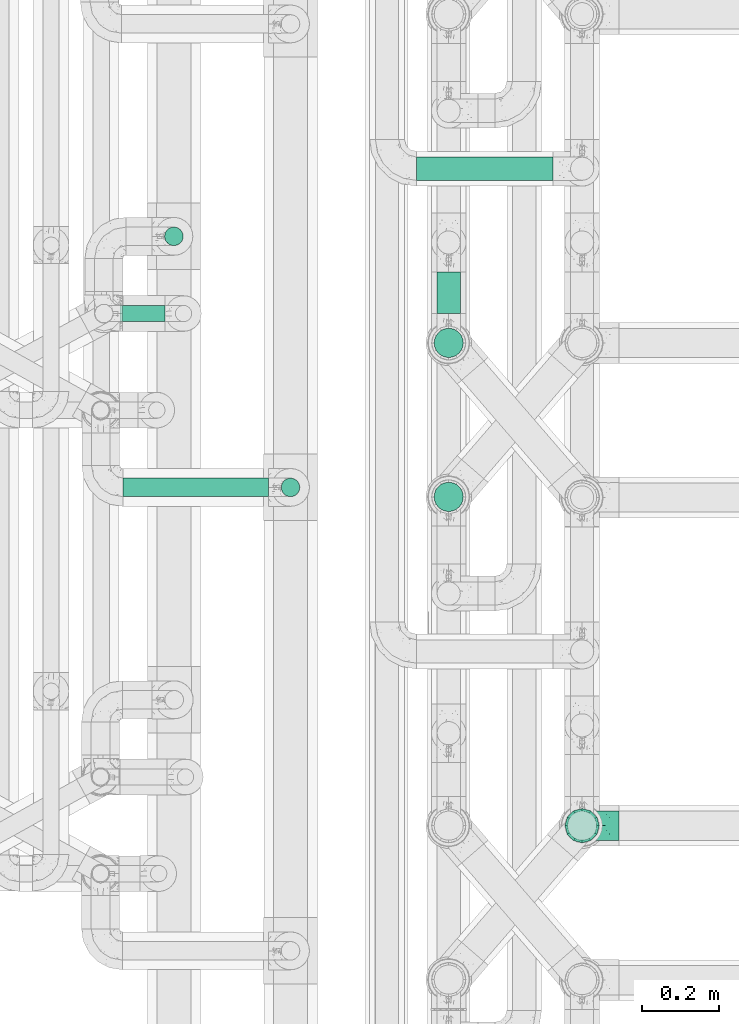
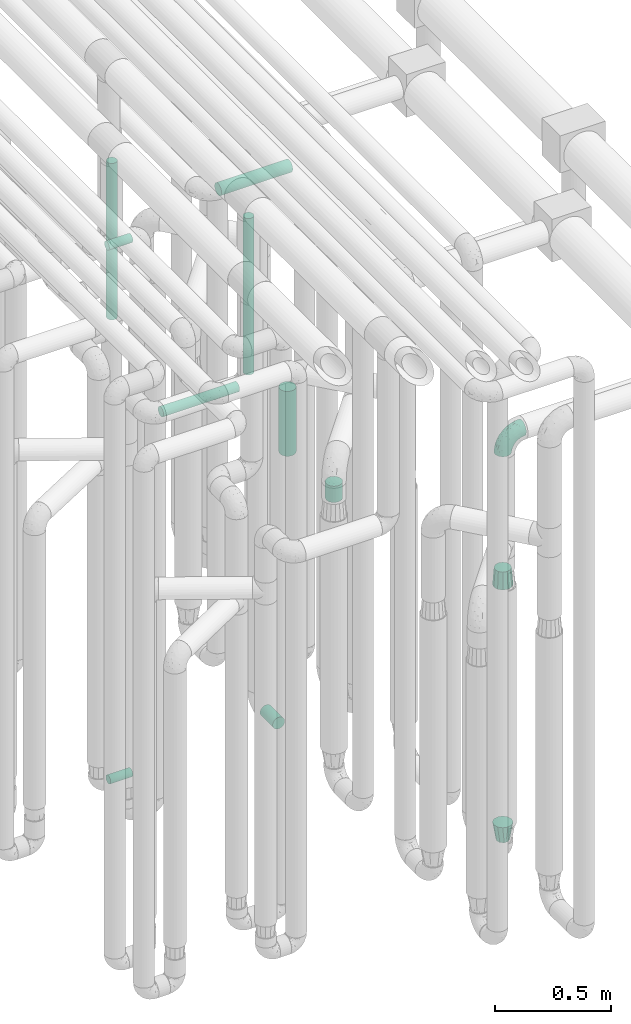
# One storey, part 614 of 827: 9 flow segments, 3 flow fittings.
"""IFC2X3 building model written with IfcOpenShell, lengths in millimetres."""

from ifc_helpers import new_model, entity, si_unit, converted_unit, derived_unit, direction, frame, origin, origin_2d_with_axis, place, context, subcontext, project, spatial, polyline, circle, outline, extrude, faceted_brep, source, transform, mapped, material, type_object, type_shapes, element, save


model = new_model("IFC2X3")

# Units and contexts
model_context = context("Model", 3, precision=0.01, world=origin(), true_north=direction((6.12303176911189e-17, 1.0)))
body_context = subcontext(model_context, "Body", "Model", "MODEL_VIEW")
ifc_project = project(units=[si_unit("LENGTHUNIT", "METRE", prefix="MILLI"), si_unit("AREAUNIT", "SQUARE_METRE"), si_unit("VOLUMEUNIT", "CUBIC_METRE"), converted_unit("PLANEANGLEUNIT", "DEGREE", entity("IfcRatioMeasure", 0.0174532925199433), si_unit("PLANEANGLEUNIT", "RADIAN"), dimensions=[0, 0, 0, 0, 0, 0, 0]), si_unit("MASSUNIT", "GRAM", prefix="KILO"), derived_unit("MASSDENSITYUNIT", [(si_unit("MASSUNIT", "GRAM", prefix="KILO"), 1), (si_unit("LENGTHUNIT", "METRE"), -3)]), derived_unit("MOMENTOFINERTIAUNIT", [(si_unit("LENGTHUNIT", "METRE"), 4)]), si_unit("TIMEUNIT", "SECOND"), si_unit("FREQUENCYUNIT", "HERTZ"), si_unit("THERMODYNAMICTEMPERATUREUNIT", "DEGREE_CELSIUS"), derived_unit("THERMALTRANSMITTANCEUNIT", [(si_unit("MASSUNIT", "GRAM", prefix="KILO"), 1), (si_unit("THERMODYNAMICTEMPERATUREUNIT", "KELVIN"), -1), (si_unit("TIMEUNIT", "SECOND"), -3)]), derived_unit("VOLUMETRICFLOWRATEUNIT", [(si_unit("LENGTHUNIT", "METRE"), 3), (si_unit("TIMEUNIT", "SECOND"), -1)]), derived_unit("MASSFLOWRATEUNIT", [(si_unit("MASSUNIT", "GRAM", prefix="KILO"), 1), (si_unit("TIMEUNIT", "SECOND"), -1)]), derived_unit("ROTATIONALFREQUENCYUNIT", [(si_unit("TIMEUNIT", "SECOND"), -1)]), si_unit("ELECTRICCURRENTUNIT", "AMPERE"), si_unit("ELECTRICVOLTAGEUNIT", "VOLT"), si_unit("POWERUNIT", "WATT"), si_unit("FORCEUNIT", "NEWTON", prefix="KILO"), si_unit("ILLUMINANCEUNIT", "LUX"), si_unit("LUMINOUSFLUXUNIT", "LUMEN"), si_unit("LUMINOUSINTENSITYUNIT", "CANDELA"), derived_unit("USERDEFINED", [(si_unit("MASSUNIT", "GRAM", prefix="KILO"), -1), (si_unit("LENGTHUNIT", "METRE"), -2), (si_unit("TIMEUNIT", "SECOND"), 3), (si_unit("LUMINOUSFLUXUNIT", "LUMEN"), 1)]), derived_unit("LINEARVELOCITYUNIT", [(si_unit("LENGTHUNIT", "METRE"), 1), (si_unit("TIMEUNIT", "SECOND"), -1)]), si_unit("PRESSUREUNIT", "PASCAL"), derived_unit("USERDEFINED", [(si_unit("LENGTHUNIT", "METRE"), -2), (si_unit("MASSUNIT", "GRAM", prefix="KILO"), 1), (si_unit("TIMEUNIT", "SECOND"), -2)]), derived_unit("LINEARFORCEUNIT", [(si_unit("MASSUNIT", "GRAM", prefix="KILO"), 1), (si_unit("LENGTHUNIT", "METRE"), 1), (si_unit("TIMEUNIT", "SECOND"), -2), (si_unit("LENGTHUNIT", "METRE"), -1)]), derived_unit("PLANARFORCEUNIT", [(si_unit("MASSUNIT", "GRAM", prefix="KILO"), 1), (si_unit("LENGTHUNIT", "METRE"), 1), (si_unit("TIMEUNIT", "SECOND"), -2), (si_unit("LENGTHUNIT", "METRE"), -2)])], contexts=[model_context])

# Site, building, storey
site_placement = place(None, origin())
site = spatial("IfcSite", under=ifc_project, at=site_placement, CompositionType="ELEMENT")
building_placement = place(site_placement, origin())
building = spatial("IfcBuilding", under=site, at=building_placement, CompositionType="ELEMENT")
storey_placement = place(building_placement, frame((0.0, 0.0, 28200.0)))
storey = spatial("IfcBuildingStorey", under=building, at=storey_placement, Name="08", CompositionType="ELEMENT", Elevation=28200.0)

# Flow segments
pipe_segment_type = type_object("IfcPipeSegmentType", PredefinedType="NOTDEFINED")
flow_segment_1_placement = place(storey_placement, frame((36546.03, 12149.58, 2968.4)))
element("IfcFlowSegment", 1, at=flow_segment_1_placement, inside=storey, type_object=pipe_segment_type, context=body_context, shape_type="SweptSolid", body=[
    extrude(circle(Radius=30.0, at=origin_2d_with_axis()), frame((0.0, 31.6, 31.6), z_axis=(1.0, 0.0, 0.0), x_axis=(0.0, -1.0, 0.0)), (0.0, 0.0, 1.0), 352.999982000026),
])
flow_segment_2_placement = place(storey_placement, frame((36598.05, 11806.2, 368.4)))
element("IfcFlowSegment", 2, at=flow_segment_2_placement, inside=storey, type_object=pipe_segment_type, context=body_context, shape_type="SweptSolid", body=[
    extrude(circle(Radius=30.0, at=origin_2d_with_axis()), frame((31.6, 0.0, 31.6), z_axis=(0.0, 1.0, 0.0), x_axis=(-1.0, 0.0, 0.0)), (0.0, 0.0, 1.0), 108.000000000014),
])
flow_segment_3_placement = place(storey_placement, frame((36590.3, 11690.86, 1870.0)))
element("IfcFlowSegment", 3, at=flow_segment_3_placement, inside=storey, type_object=pipe_segment_type, context=body_context, shape_type="SweptSolid", body=[
    extrude(circle(Radius=37.75, at=origin_2d_with_axis()), frame((39.35, 39.35, 0.0)), (0.0, 0.0, 1.0), 340.000000000014),
])
flow_segment_4_placement = place(storey_placement, frame((36590.3, 11292.25, 1870.0)))
element("IfcFlowSegment", 4, at=flow_segment_4_placement, inside=storey, type_object=pipe_segment_type, context=body_context, shape_type="SweptSolid", body=[
    extrude(circle(Radius=37.75, at=origin_2d_with_axis()), frame((39.35, 39.35, 0.0)), (0.0, 0.0, 1.0), 84.9999999999937),
])
flow_segment_5_placement = place(storey_placement, frame((35784.85, 11783.46, 377.25)))
element("IfcFlowSegment", 5, at=flow_segment_5_placement, inside=storey, type_object=pipe_segment_type, context=body_context, shape_type="SweptSolid", body=[
    extrude(circle(Radius=21.15, at=origin_2d_with_axis()), frame((0.0, 22.75, 22.75), z_axis=(1.0, 0.0, 0.0), x_axis=(0.0, 1.0, 0.0)), (0.0, 0.0, 1.0), 110.194459668835),
])
flow_segment_6_placement = place(storey_placement, frame((35778.03, 11783.46, 3177.25)))
element("IfcFlowSegment", 6, at=flow_segment_6_placement, inside=storey, type_object=pipe_segment_type, context=body_context, shape_type="SweptSolid", body=[
    extrude(circle(Radius=21.15, at=origin_2d_with_axis()), frame((0.0, 22.75, 22.75), z_axis=(1.0, 0.0, 0.0), x_axis=(0.0, 1.0, 0.0)), (0.0, 0.0, 1.0), 117.013860378015),
])
flow_segment_7_placement = place(storey_placement, frame((35892.47, 11980.49, 2657.0)))
element("IfcFlowSegment", 7, at=flow_segment_7_placement, inside=storey, type_object=pipe_segment_type, context=body_context, shape_type="SweptSolid", body=[
    extrude(circle(Radius=24.0, at=origin_2d_with_axis()), frame((25.6, 25.6, 0.0)), (0.0, 0.0, 1.0), 820.000751547978),
])
flow_segment_8_placement = place(storey_placement, frame((35785.78, 11330.49, 2574.4)))
element("IfcFlowSegment", 8, at=flow_segment_8_placement, inside=storey, type_object=pipe_segment_type, context=body_context, shape_type="SweptSolid", body=[
    extrude(circle(Radius=24.0, at=origin_2d_with_axis()), frame((0.0, 25.6, 25.6), z_axis=(1.0, 0.0, 0.0), x_axis=(0.0, -1.0, 0.0)), (0.0, 0.0, 1.0), 377.249999999815),
])
flow_segment_9_placement = place(storey_placement, frame((36194.44, 11330.49, 2657.0)))
element("IfcFlowSegment", 9, at=flow_segment_9_placement, inside=storey, type_object=pipe_segment_type, context=body_context, shape_type="SweptSolid", body=[
    extrude(outline(polyline([(-3.13, -23.79), (3.13, -23.79), (9.18, -22.17), (14.61, -19.04), (19.04, -14.61), (22.17, -9.18), (23.79, -3.13), (23.79, 3.13), (22.17, 9.18), (19.04, 14.61), (14.61, 19.04), (9.18, 22.17), (3.13, 23.79), (-3.13, 23.79), (-9.18, 22.17), (-14.61, 19.04), (-19.04, 14.61), (-22.17, 9.18), (-23.79, 3.13), (-23.79, -3.13), (-22.17, -9.18), (-19.04, -14.61), (-14.61, -19.04), (-9.18, -22.17), (-3.13, -23.79)])), frame((25.6, 25.6, 0.0), z_axis=(0.0, -8.11528883373535e-09, 1.0), x_axis=(-0.130526192219642, 0.991444861373864, 8.04589959840434e-09)), (0.0, 0.0, 1.0), 820.00018792874),
])

# Flow fittings
ifc_material = material()
pipe_fitting_type_1 = type_object("IfcPipeFittingType", Name="ADSK_1", PredefinedType="NOTDEFINED", material=ifc_material)
shared_shape_1 = source(origin(), body_context, "Body", "Brep", [
    faceted_brep([(-95.0, 19.02, -32.95), (-95.0, 9.85, -36.75), (-95.0, 0.0, -38.05), (-95.0, -9.85, -36.75), (-95.0, -19.03, -32.95), (-95.0, -26.91, -26.91), (-95.0, -32.95, -19.03), (-95.0, -36.75, -9.85), (-95.0, -38.05, 0.0), (-95.0, -36.75, 9.85), (-95.0, -32.95, 19.02), (-95.0, -26.91, 26.91), (-95.0, -19.03, 32.95), (-95.0, -9.85, 36.75), (-95.0, 0.0, 38.05), (-95.0, 9.85, 36.75), (-95.0, 19.02, 32.95), (-95.0, 26.91, 26.91), (-95.0, 32.95, 19.02), (-95.0, 36.75, 9.85), (-95.0, 38.05, 0.0), (-95.0, 36.75, -9.85), (-95.0, 32.95, -19.03), (-95.0, 26.91, -26.91), (0.0, 95.0, -38.05), (-9.85, 95.0, -36.75), (-19.02, 95.0, -32.95), (-26.91, 95.0, -26.91), (-32.95, 95.0, -19.03), (-36.75, 95.0, -9.85), (-38.05, 95.0, 0.0), (-36.75, 95.0, 9.85), (-32.95, 95.0, 19.02), (-26.91, 95.0, 26.91), (-19.02, 95.0, 32.95), (-9.85, 95.0, 36.75), (0.0, 95.0, 38.05), (9.85, 95.0, 36.75), (19.03, 95.0, 32.95), (26.91, 95.0, 26.91), (32.95, 95.0, 19.02), (36.75, 95.0, 9.85), (38.05, 95.0, 0.0), (36.75, 95.0, -9.85), (32.95, 95.0, -19.03), (26.91, 95.0, -26.91), (19.03, 95.0, -32.95), (9.85, 95.0, -36.75), (-7.99, -4.96, 6.3), (-0.92, 0.92, 0.0), (4.62, 8.1, 8.01), (-76.19, -35.57, 0.0), (-64.32, -32.32, 12.43), (20.51, 62.45, 28.68), (-60.56, -33.52, 0.0), (-70.4, -13.47, 34.42), (-39.61, -5.88, 32.32), (-49.6, 2.07, 37.1), (-70.34, -28.81, 21.71), (14.64, 40.81, 26.5), (5.88, 39.61, 32.32), (3.59, 20.77, 25.31), (-40.45, 68.06, 16.75), (-62.45, -20.51, 28.68), (-44.52, -26.87, 0.0), (-28.47, -20.22, 0.0), (-26.43, -17.83, 8.75), (-76.1, 39.63, 10.76), (-72.74, 37.58, 18.19), (-60.35, 46.18, 14.61), (-13.4, 13.4, 32.12), (-20.77, -3.59, 25.31), (-14.66, 81.47, 35.56), (-6.22, 71.26, 37.92), (-57.5, 42.48, 22.79), (-15.0, 34.74, 37.7), (-27.1, 12.08, 36.05), (-9.2, 28.81, 35.63), (-79.98, 23.7, 30.95), (-73.68, -4.3, 37.48), (-30.74, 21.67, 37.97), (-62.36, 47.59, 6.79), (-72.71, 32.83, 24.69), (-67.42, 7.02, 37.95), (-32.13, 75.27, 24.51), (-43.46, 51.47, 26.26), (-24.98, 73.15, 31.29), (20.59, 41.28, 19.85), (7.79, 16.09, 15.86), (-73.21, 42.39, 0.0), (-54.73, 54.73, 0.0), (-73.44, 15.79, 35.79), (-5.94, 4.32, 20.43), (28.81, 70.34, 21.71), (32.32, 64.32, 12.43), (-53.59, 26.2, 35.09), (-52.02, 19.31, 37.21), (21.38, 33.53, 10.34), (26.87, 44.52, 0.0), (-48.28, 12.14, 38.05), (4.3, 73.68, 37.48), (-44.08, -25.52, 12.79), (-41.28, -20.59, 19.85), (35.57, 76.19, 0.0), (-47.26, 54.3, 20.18), (-47.4, 61.99, 8.58), (-42.39, 73.21, 0.0), (-39.67, 78.86, 7.21), (-45.69, 36.84, 33.11), (-32.83, 50.13, 33.35), (13.47, 70.4, 34.42), (-18.25, 63.73, 36.07), (-40.63, -13.75, 27.22), (-16.63, 46.37, 37.95), (-53.47, 38.79, 28.59), (-26.07, 48.54, 36.15), (-34.51, 34.51, 36.86), (-2.07, 49.6, 37.1), (-22.79, -10.49, 19.23), (-61.73, 28.67, 31.87), (9.65, 14.7, 0.0), (20.22, 28.47, 0.0), (33.52, 60.56, 0.0), (-11.42, -5.44, 13.25), (-14.7, -9.65, 0.0), (-81.47, 14.66, -35.56), (-62.45, -20.51, -28.68), (-71.26, 6.22, -37.92), (-75.27, 32.13, -24.51), (-73.15, 24.98, -31.29), (13.47, 70.4, -34.42), (5.88, 39.61, -32.32), (-2.07, 49.6, -37.1), (-78.86, 39.67, -7.21), (-70.4, -13.47, -34.42), (-39.61, -5.88, -32.32), (-61.99, 47.4, -8.58), (32.32, 64.32, -12.43), (28.81, 70.34, -21.71), (-63.73, 18.25, -36.07), (-50.13, 32.83, -33.35), (4.3, 73.68, -37.48), (-7.02, 67.42, -37.95), (-39.63, 76.1, -10.76), (-46.18, 60.35, -14.61), (-47.59, 62.36, -6.79), (-64.32, -32.32, -12.43), (-26.2, 53.59, -35.09), (-15.79, 73.44, -35.79), (-19.31, 52.02, -37.21), (-37.58, 72.74, -18.19), (-70.34, -28.81, -21.71), (-42.48, 57.5, -22.79), (-38.79, 53.47, -28.59), (-51.47, 43.46, -26.26), (-32.83, 72.71, -24.69), (-46.37, 16.63, -37.95), (-73.68, -4.3, -37.48), (-41.28, -20.59, -19.85), (-44.08, -25.52, -12.79), (13.75, 40.63, -27.22), (20.51, 62.45, -28.68), (-68.06, 40.45, -16.75), (-54.3, 47.26, -20.18), (-12.14, 48.28, -38.05), (-21.67, 30.74, -37.97), (-36.84, 45.69, -33.11), (-11.42, -5.44, -13.25), (7.79, 16.09, -15.86), (4.62, 8.1, -8.01), (-23.7, 79.98, -30.95), (-26.43, -17.83, -8.75), (-7.99, -4.96, -6.3), (-40.81, -14.64, -26.5), (-20.77, -3.59, -25.31), (-34.74, 15.0, -37.7), (-12.08, 27.1, -36.05), (-28.81, 9.2, -35.63), (-22.79, -10.49, -19.23), (21.38, 33.53, -10.34), (20.59, 41.28, -19.85), (-48.54, 26.07, -36.15), (-49.6, 2.07, -37.1), (-13.4, 13.4, -32.12), (3.59, 20.77, -25.31), (-28.67, 61.73, -31.87), (-34.51, 34.51, -36.86), (-5.94, 4.32, -20.43)], [[[0, 1, 2, 3, 4, 5, 6, 7, 8, 9, 10, 11, 12, 13, 14, 15, 16, 17, 18, 19, 20, 21, 22, 23]], [[24, 25, 26, 27, 28, 29, 30, 31, 32, 33, 34, 35, 36, 37, 38, 39, 40, 41, 42, 43, 44, 45, 46, 47]], [[48, 49, 50]], [[51, 52, 9]], [[53, 39, 38]], [[9, 52, 10]], [[54, 52, 51]], [[55, 56, 57]], [[11, 10, 58]], [[59, 60, 61]], [[32, 31, 62]], [[63, 12, 11]], [[63, 55, 12]], [[64, 65, 66]], [[67, 68, 69]], [[70, 56, 71]], [[35, 72, 73]], [[69, 68, 74]], [[75, 76, 77]], [[16, 78, 17]], [[13, 79, 14]], [[76, 75, 80]], [[67, 69, 81]], [[18, 17, 82]], [[14, 79, 83]], [[20, 19, 67]], [[84, 85, 86]], [[87, 61, 88]], [[89, 81, 90]], [[18, 82, 68]], [[15, 91, 16]], [[14, 83, 15]], [[71, 92, 61]], [[17, 78, 82]], [[93, 87, 94]], [[95, 91, 96]], [[97, 98, 94]], [[86, 72, 34]], [[96, 99, 80]], [[37, 36, 100]], [[40, 39, 93]], [[40, 94, 41]], [[64, 66, 101]], [[93, 94, 40]], [[58, 102, 63]], [[94, 103, 41]], [[94, 87, 97]], [[104, 69, 74]], [[34, 33, 86]], [[105, 69, 104]], [[52, 58, 10]], [[106, 107, 30]], [[108, 109, 85]], [[105, 106, 90]], [[53, 110, 60]], [[86, 111, 72]], [[86, 109, 111]], [[33, 84, 86]], [[12, 55, 13]], [[112, 56, 63]], [[110, 38, 37]], [[34, 72, 35]], [[36, 35, 73]], [[111, 113, 73]], [[105, 107, 106]], [[110, 53, 38]], [[74, 114, 85]], [[91, 15, 83]], [[105, 90, 81]], [[107, 62, 31]], [[33, 32, 84]], [[115, 109, 116]], [[111, 115, 113]], [[100, 73, 117]], [[56, 55, 63]], [[79, 55, 57]], [[102, 118, 112]], [[56, 70, 76]], [[100, 110, 37]], [[117, 77, 60]], [[117, 60, 110]], [[60, 70, 61]], [[58, 52, 101]], [[63, 11, 58]], [[39, 53, 93]], [[87, 93, 53]], [[96, 91, 83]], [[78, 91, 119]], [[32, 62, 84]], [[84, 62, 104]], [[86, 85, 109]], [[85, 114, 108]], [[80, 113, 116]], [[117, 73, 113]], [[80, 116, 96]], [[80, 57, 76]], [[71, 112, 118]], [[61, 87, 59]], [[62, 107, 105]], [[97, 120, 121]], [[70, 71, 61]], [[71, 118, 92]], [[73, 100, 36]], [[110, 100, 117]], [[55, 79, 13]], [[83, 79, 57]], [[96, 83, 99]], [[116, 108, 95]], [[50, 97, 88]], [[97, 87, 88]], [[50, 49, 120]], [[122, 94, 98]], [[89, 20, 67]], [[105, 81, 69]], [[89, 67, 81]], [[68, 19, 18]], [[68, 67, 19]], [[74, 68, 82]], [[114, 82, 119]], [[74, 85, 104]], [[82, 114, 74]], [[114, 119, 108]], [[95, 108, 119]], [[116, 109, 108]], [[123, 48, 50]], [[97, 50, 120]], [[123, 50, 88]], [[91, 95, 119]], [[116, 95, 96]], [[84, 104, 85]], [[104, 62, 105]], [[83, 57, 99]], [[57, 80, 99]], [[66, 48, 123]], [[66, 124, 48]], [[118, 66, 123]], [[124, 66, 65]], [[66, 118, 101]], [[54, 64, 52]], [[124, 49, 48]], [[30, 107, 31]], [[91, 78, 16]], [[82, 78, 119]], [[56, 76, 57]], [[77, 76, 70]], [[60, 77, 70]], [[77, 117, 75]], [[117, 113, 75]], [[113, 80, 75]], [[9, 8, 51]], [[103, 94, 122]], [[103, 42, 41]], [[73, 72, 111]], [[113, 115, 116]], [[111, 109, 115]], [[102, 112, 63]], [[71, 56, 112]], [[118, 102, 101]], [[92, 123, 88]], [[123, 92, 118]], [[61, 92, 88]], [[87, 53, 59]], [[60, 59, 53]], [[97, 121, 98]], [[58, 101, 102]], [[64, 101, 52]], [[125, 1, 0]], [[126, 5, 4]], [[2, 1, 127]], [[1, 125, 127]], [[128, 129, 23]], [[130, 131, 132]], [[89, 133, 20]], [[126, 134, 135]], [[136, 89, 90]], [[137, 138, 44]], [[139, 129, 140]], [[24, 141, 142]], [[143, 144, 145]], [[125, 129, 139]], [[6, 146, 7]], [[147, 148, 149]], [[146, 51, 7]], [[143, 150, 144]], [[146, 6, 151]], [[152, 153, 154]], [[126, 4, 134]], [[0, 23, 129]], [[28, 155, 150]], [[43, 42, 103]], [[54, 146, 64]], [[139, 156, 127]], [[157, 3, 2]], [[151, 158, 159]], [[160, 131, 161]], [[22, 21, 162]], [[136, 144, 163]], [[149, 164, 165]], [[24, 142, 25]], [[166, 140, 154]], [[154, 129, 128]], [[143, 30, 29]], [[167, 168, 169]], [[155, 28, 27]], [[26, 170, 27]], [[171, 167, 172]], [[26, 25, 148]], [[27, 170, 155]], [[173, 135, 174]], [[144, 150, 152]], [[175, 176, 177]], [[24, 47, 141]], [[45, 161, 46]], [[148, 25, 142]], [[176, 175, 165]], [[64, 159, 171]], [[138, 45, 44]], [[130, 46, 161]], [[137, 44, 43]], [[178, 159, 158]], [[137, 103, 122]], [[163, 144, 152]], [[136, 133, 89]], [[103, 137, 43]], [[6, 5, 151]], [[178, 158, 173]], [[134, 4, 3]], [[178, 173, 174]], [[137, 98, 179]], [[145, 90, 106]], [[138, 180, 161]], [[46, 130, 47]], [[136, 90, 145]], [[133, 162, 21]], [[23, 22, 128]], [[139, 140, 181]], [[139, 181, 156]], [[157, 127, 182]], [[157, 134, 3]], [[182, 177, 135]], [[182, 135, 134]], [[135, 183, 174]], [[131, 130, 161]], [[141, 130, 132]], [[160, 180, 184]], [[131, 183, 176]], [[5, 126, 151]], [[158, 151, 126]], [[180, 138, 137]], [[161, 45, 138]], [[149, 148, 142]], [[170, 148, 185]], [[22, 162, 128]], [[128, 162, 163]], [[129, 154, 140]], [[154, 153, 166]], [[165, 156, 186]], [[182, 127, 156]], [[165, 186, 149]], [[165, 132, 176]], [[131, 184, 183]], [[187, 167, 178]], [[184, 168, 187]], [[167, 169, 172]], [[184, 180, 168]], [[174, 183, 184]], [[127, 157, 2]], [[134, 157, 182]], [[130, 141, 47]], [[142, 141, 132]], [[149, 142, 164]], [[186, 166, 147]], [[180, 179, 168]], [[169, 179, 120]], [[137, 179, 180]], [[179, 121, 120]], [[106, 30, 143]], [[136, 145, 144]], [[106, 143, 145]], [[150, 29, 28]], [[150, 143, 29]], [[152, 150, 155]], [[153, 155, 185]], [[152, 154, 163]], [[155, 153, 152]], [[153, 185, 166]], [[147, 166, 185]], [[186, 140, 166]], [[169, 120, 49]], [[169, 49, 172]], [[179, 169, 168]], [[148, 147, 185]], [[186, 147, 149]], [[128, 163, 154]], [[163, 162, 136]], [[142, 132, 164]], [[132, 165, 164]], [[171, 124, 65]], [[124, 171, 172]], [[64, 146, 159]], [[171, 159, 178]], [[171, 65, 64]], [[172, 49, 124]], [[162, 133, 136]], [[20, 133, 21]], [[148, 170, 26]], [[155, 170, 185]], [[131, 176, 132]], [[177, 176, 183]], [[135, 177, 183]], [[177, 182, 175]], [[182, 156, 175]], [[156, 165, 175]], [[51, 146, 54]], [[51, 8, 7]], [[129, 125, 0]], [[127, 125, 139]], [[140, 186, 181]], [[156, 181, 186]], [[158, 126, 173]], [[135, 173, 126]], [[187, 178, 174]], [[171, 178, 167]], [[184, 187, 174]], [[167, 187, 168]], [[180, 160, 161]], [[184, 131, 160]], [[98, 137, 122]], [[98, 121, 179]], [[151, 159, 146]]]),
])
type_shapes(pipe_fitting_type_1, [shared_shape_1])
flow_fitting_1_placement = place(storey_placement, frame((36975.03, 10480.2, 2600.0), z_axis=(0.0, 1.0, 0.0), x_axis=(0.0, 0.0, 1.0)))
element("IfcFlowFitting", 10, at=flow_fitting_1_placement, inside=storey, type_object=pipe_fitting_type_1, material=ifc_material, Name="ADSK_1", ObjectType="ADSK_1", context=body_context, shape_type="MappedRepresentation", body=[
    mapped(shared_shape_1, transform((0.0, 0.0, 0.0), scale=1.0)),
])
pipe_fitting_type_2 = type_object("IfcPipeFittingType", Name="ADSK_1", PredefinedType="NOTDEFINED", material=ifc_material)
shared_shape_2 = source(origin(), body_context, "Body", "Brep", [
    faceted_brep([(89.0, 38.05, 0.0), (89.0, 35.5, 9.51), (89.0, 32.95, 19.03), (89.0, 25.99, 25.99), (89.0, 19.02, 32.95), (89.0, 9.51, 35.5), (89.0, 0.0, 38.05), (89.0, -9.51, 35.5), (89.0, -19.03, 32.95), (89.0, -25.99, 25.99), (89.0, -32.95, 19.03), (89.0, -35.5, 9.51), (89.0, -38.05, 0.0), (89.0, -35.5, -9.51), (89.0, -32.95, -19.02), (89.0, -25.99, -25.99), (89.0, -19.03, -32.95), (89.0, -9.51, -35.5), (89.0, 0.0, -38.05), (89.0, 9.51, -35.5), (89.0, 19.02, -32.95), (89.0, 25.99, -25.99), (89.0, 32.95, -19.03), (89.0, 35.5, -9.51), (0.0, -38.49, 22.22), (0.0, -30.36, 30.36), (0.0, -22.22, 38.49), (0.0, -11.11, 41.47), (0.0, 0.0, 44.45), (0.0, 11.11, 41.47), (0.0, 22.23, 38.49), (0.0, 30.36, 30.36), (0.0, 38.49, 22.22), (0.0, 41.96, 9.31), (0.0, 44.45, 0.0), (0.0, 41.47, -11.11), (0.0, 38.49, -22.23), (0.0, 30.36, -30.36), (0.0, 22.23, -38.49), (0.0, 11.11, -41.47), (0.0, 0.0, -44.45), (0.0, -11.11, -41.47), (0.0, -22.23, -38.49), (0.0, -30.36, -30.36), (0.0, -38.49, -22.23), (0.0, -41.96, -9.31), (0.0, -44.45, 0.0), (0.0, -41.47, 11.11)], [[[0, 1, 2, 3, 4, 5, 6, 7, 8, 9, 10, 11, 12, 13, 14, 15, 16, 17, 18, 19, 20, 21, 22, 23]], [[24, 25, 26, 27, 28, 29, 30, 31, 32, 33, 34, 35, 36, 37, 38, 39, 40, 41, 42, 43, 44, 45, 46, 47]], [[23, 22, 36, 35, 34, 0]], [[39, 38, 20, 19, 18, 40]], [[38, 37, 36, 22, 21, 20]], [[43, 42, 16, 15, 14, 44]], [[41, 40, 18, 17, 16, 42]], [[12, 46, 45, 44, 14, 13]], [[11, 10, 24, 47, 46, 12]], [[27, 26, 8, 7, 6, 28]], [[26, 25, 24, 10, 9, 8]], [[31, 30, 4, 3, 2, 32]], [[29, 28, 6, 5, 4, 30]], [[0, 34, 33, 32, 2, 1]]]),
])
type_shapes(pipe_fitting_type_2, [shared_shape_2])
flow_fitting_2_placement = place(storey_placement, frame((36975.03, 10480.2, 1811.0), z_axis=(1.0, 0.0, 0.0), x_axis=(0.0, 0.0, 1.0)))
element("IfcFlowFitting", 11, at=flow_fitting_2_placement, inside=storey, type_object=pipe_fitting_type_2, material=ifc_material, Name="ADSK_1", ObjectType="ADSK_1", context=body_context, shape_type="MappedRepresentation", body=[
    mapped(shared_shape_2, transform((0.0, 0.0, 0.0), scale=1.0)),
])
pipe_fitting_type_3 = type_object("IfcPipeFittingType", Name="ADSK_1", PredefinedType="NOTDEFINED", material=ifc_material)
shared_shape_3 = source(origin(), body_context, "Body", "Brep", [
    faceted_brep([(89.0, 38.49, -22.22), (89.0, 42.1, -8.76), (89.0, 44.45, 0.0), (89.0, 42.1, 8.76), (89.0, 38.49, 22.23), (89.0, 30.36, 30.36), (89.0, 22.23, 38.49), (89.0, 11.11, 41.47), (89.0, 0.0, 44.45), (89.0, -11.11, 41.47), (89.0, -22.22, 38.49), (89.0, -30.36, 30.36), (89.0, -38.49, 22.23), (89.0, -42.1, 8.76), (89.0, -44.45, 0.0), (89.0, -42.1, -8.76), (89.0, -38.49, -22.22), (89.0, -30.36, -30.36), (89.0, -22.22, -38.49), (89.0, -11.11, -41.47), (89.0, 0.0, -44.45), (89.0, 11.11, -41.47), (89.0, 22.23, -38.49), (89.0, 30.36, -30.36), (0.0, -24.39, -17.72), (0.0, -27.27, -8.86), (0.0, -30.15, 0.0), (0.0, -27.27, 8.86), (0.0, -24.39, 17.72), (0.0, -16.85, 23.2), (0.0, -9.32, 28.67), (0.0, 0.0, 28.67), (0.0, 9.32, 28.67), (0.0, 16.85, 23.2), (0.0, 24.39, 17.72), (0.0, 27.27, 8.86), (0.0, 30.15, 0.0), (0.0, 27.27, -8.86), (0.0, 24.39, -17.72), (0.0, 16.85, -23.2), (0.0, 9.32, -28.67), (0.0, 0.0, -28.67), (0.0, -9.32, -28.67), (0.0, -16.85, -23.2)], [[[0, 1, 2, 3, 4, 5, 6, 7, 8, 9, 10, 11, 12, 13, 14, 15, 16, 17, 18, 19, 20, 21, 22, 23]], [[24, 25, 26, 27, 28, 29, 30, 31, 32, 33, 34, 35, 36, 37, 38, 39, 40, 41, 42, 43]], [[38, 37, 0]], [[41, 19, 42]], [[40, 21, 41]], [[15, 14, 26]], [[39, 38, 23]], [[2, 1, 36]], [[37, 36, 1]], [[43, 42, 18]], [[37, 1, 0]], [[23, 22, 39]], [[23, 38, 0]], [[26, 25, 15]], [[17, 16, 24]], [[15, 25, 16]], [[19, 18, 42]], [[17, 24, 43]], [[16, 25, 24]], [[22, 40, 39]], [[17, 43, 18]], [[20, 19, 41]], [[20, 41, 21]], [[40, 22, 21]], [[28, 27, 12]], [[31, 7, 32]], [[30, 9, 31]], [[3, 2, 36]], [[29, 28, 11]], [[14, 13, 26]], [[27, 26, 13]], [[33, 32, 6]], [[27, 13, 12]], [[11, 10, 29]], [[11, 28, 12]], [[36, 35, 3]], [[5, 4, 34]], [[3, 35, 4]], [[7, 6, 32]], [[5, 34, 33]], [[4, 35, 34]], [[10, 30, 29]], [[5, 33, 6]], [[8, 7, 31]], [[8, 31, 9]], [[30, 10, 9]]]),
])
type_shapes(pipe_fitting_type_3, [shared_shape_3])
flow_fitting_3_placement = place(storey_placement, frame((36975.03, 10480.2, 476.0), z_axis=(0.0, 1.0, 0.0), x_axis=(0.0, 0.0, 1.0)))
element("IfcFlowFitting", 12, at=flow_fitting_3_placement, inside=storey, type_object=pipe_fitting_type_3, material=ifc_material, Name="ADSK_1", ObjectType="ADSK_1", context=body_context, shape_type="MappedRepresentation", body=[
    mapped(shared_shape_3, transform((0.0, 0.0, 0.0), scale=1.0)),
])

save(model, "model.ifc")
